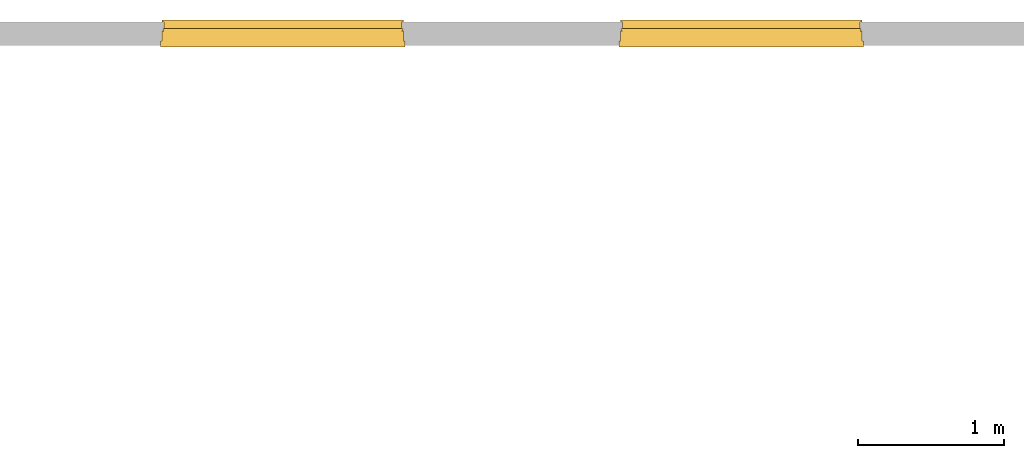
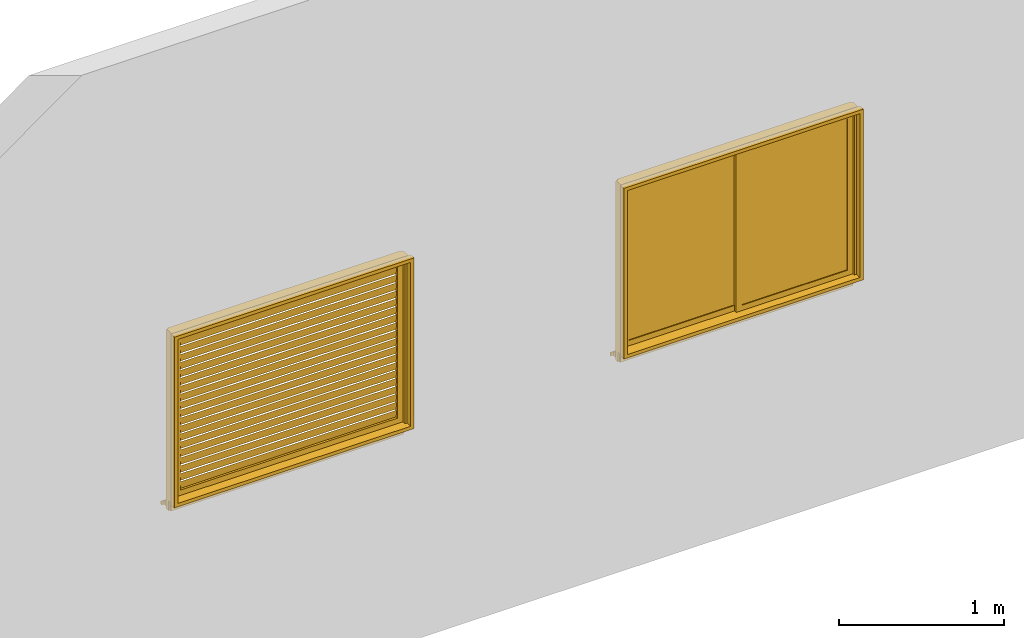
# One storey, part 2 of 3: 2 windows.
"""IFC2X3 building model written with IfcOpenShell, lengths in millimetres."""

from ifc_helpers import new_model, entity, si_unit, converted_unit, derived_unit, money_unit, direction, frame, origin_with_axes, place, context, subcontext, project, spatial, open_shell, faceted_brep, surface_model, type_object, element, save


model = new_model("IFC2X3")

# Units and contexts
model_context = context("Model", 3, precision=1e-05, world=origin_with_axes(), true_north=direction((0.0, 1.0)))
body_context = subcontext(model_context, "Body", "Model", "MODEL_VIEW")
ifc_project = project(units=[si_unit("LENGTHUNIT", "METRE", prefix="MILLI"), si_unit("AREAUNIT", "SQUARE_METRE"), si_unit("VOLUMEUNIT", "CUBIC_METRE"), converted_unit("PLANEANGLEUNIT", "DEGREE", entity("IfcPlaneAngleMeasure", 0.0174532925199), si_unit("PLANEANGLEUNIT", "RADIAN"), dimensions=[0, 0, 0, 0, 0, 0, 0]), si_unit("SOLIDANGLEUNIT", "STERADIAN"), money_unit("JPY"), converted_unit("TIMEUNIT", "Year", entity("IfcTimeMeasure", 31556926.0), si_unit("TIMEUNIT", "SECOND"), dimensions=[0, 0, 1, 0, 0, 0, 0]), si_unit("MASSUNIT", "GRAM", prefix="KILO"), si_unit("THERMODYNAMICTEMPERATUREUNIT", "DEGREE_CELSIUS"), si_unit("LUMINOUSINTENSITYUNIT", "LUMEN"), si_unit("ENERGYUNIT", "JOULE", prefix="MEGA"), derived_unit("THERMALCONDUCTANCEUNIT", [(si_unit("POWERUNIT", "WATT"), 1), (si_unit("LENGTHUNIT", "METRE"), -1), (si_unit("THERMODYNAMICTEMPERATUREUNIT", "KELVIN"), -1)]), derived_unit("SPECIFICHEATCAPACITYUNIT", [(si_unit("ENERGYUNIT", "JOULE"), 1), (si_unit("MASSUNIT", "GRAM", prefix="KILO"), -1), (si_unit("THERMODYNAMICTEMPERATUREUNIT", "KELVIN"), -1)]), derived_unit("MASSDENSITYUNIT", [(si_unit("MASSUNIT", "GRAM", prefix="KILO"), 1), (si_unit("VOLUMEUNIT", "CUBIC_METRE"), -1)])], contexts=[model_context])

# Site, building, storey
site_placement = place(None, origin_with_axes())
site = spatial("IfcSite", under=ifc_project, at=site_placement, CompositionType="ELEMENT")
building_placement = place(site_placement, origin_with_axes())
building = spatial("IfcBuilding", under=site, at=building_placement, CompositionType="ELEMENT")
storey_placement = place(building_placement, origin_with_axes())
storey = spatial("IfcBuildingStorey", under=building, at=storey_placement, Name="1FL", CompositionType="ELEMENT", Elevation=0.0)

# Windows
window_style_1 = type_object("IfcWindowStyle", ConstructionType="NOTDEFINED", OperationType="NOTDEFINED", ParameterTakesPrecedence=False, Sizeable=False)
window_1_placement = place(storey_placement, frame((-4117.13257315, -2483.59976003, 1600.0), z_axis=(0.0, 0.0, 1.0), x_axis=(1.0, 0.0, 0.0)))
element("IfcWindow", 1, at=window_1_placement, inside=storey, type_object=window_style_1, Name="AW2", OverallHeight=1350.0, OverallWidth=1720.0, context=body_context, shape_type="SurfaceModel", body=[
    faceted_brep([(0.0, -5.0, 0.0), (1600.0, -5.0, 0.0), (1600.0, -25.0, 0.0), (0.0, -25.0, 0.0), (0.0, -5.0, 1200.0), (1600.0, -5.0, 1200.0), (40.0, -5.0, 40.0), (1560.0, -5.0, 40.0), (1560.0, -5.0, 1160.0), (40.0, -5.0, 1160.0), (1600.0, -25.0, 1200.0), (0.0, -25.0, 1200.0), (40.0, -25.0, 40.0), (40.0, -25.0, 1160.0), (1560.0, -25.0, 1160.0), (1560.0, -25.0, 40.0)], [[[0, 1, 2, 3]], [[0, 4, 5, 1], [6, 7, 8, 9]], [[1, 5, 10, 2]], [[3, 2, 10, 11], [12, 13, 14, 15]], [[4, 0, 3, 11]], [[5, 4, 11, 10]], [[7, 6, 12, 15]], [[8, 7, 15, 14]], [[9, 8, 14, 13]], [[6, 9, 13, 12]]]),
    surface_model("IfcShellBasedSurfaceModel", [(1560.0, -9.86239832224, 40.336897219), (40.0, -9.86239832224, 40.336897219), (40.0, -20.1376016778, 98.610471202), (1560.0, -20.1376016778, 98.610471202)], [open_shell([[[0, 1, 2, 3]]])]),
    surface_model("IfcShellBasedSurfaceModel", [(1560.0, -9.86239832224, 99.2842656401), (40.0, -9.86239832224, 99.2842656401), (40.0, -20.1376016778, 157.557839623), (1560.0, -20.1376016778, 157.557839623)], [open_shell([[[0, 1, 2, 3]]])]),
    surface_model("IfcShellBasedSurfaceModel", [(1560.0, -9.86239832224, 158.231634061), (40.0, -9.86239832224, 158.231634061), (40.0, -20.1376016778, 216.505208044), (1560.0, -20.1376016778, 216.505208044)], [open_shell([[[0, 1, 2, 3]]])]),
    surface_model("IfcShellBasedSurfaceModel", [(1560.0, -9.86239832224, 217.179002482), (40.0, -9.86239832224, 217.179002482), (40.0, -20.1376016778, 275.452576465), (1560.0, -20.1376016778, 275.452576465)], [open_shell([[[0, 1, 2, 3]]])]),
    surface_model("IfcShellBasedSurfaceModel", [(1560.0, -9.86239832224, 276.126370903), (40.0, -9.86239832224, 276.126370903), (40.0, -20.1376016778, 334.399944886), (1560.0, -20.1376016778, 334.399944886)], [open_shell([[[0, 1, 2, 3]]])]),
    surface_model("IfcShellBasedSurfaceModel", [(1560.0, -9.86239832224, 335.073739324), (40.0, -9.86239832224, 335.073739324), (40.0, -20.1376016778, 393.347313307), (1560.0, -20.1376016778, 393.347313307)], [open_shell([[[0, 1, 2, 3]]])]),
    surface_model("IfcShellBasedSurfaceModel", [(1560.0, -9.86239832224, 394.021107745), (40.0, -9.86239832224, 394.021107745), (40.0, -20.1376016778, 452.294681728), (1560.0, -20.1376016778, 452.294681728)], [open_shell([[[0, 1, 2, 3]]])]),
    surface_model("IfcShellBasedSurfaceModel", [(1560.0, -9.86239832224, 452.968476166), (40.0, -9.86239832224, 452.968476166), (40.0, -20.1376016778, 511.242050149), (1560.0, -20.1376016778, 511.242050149)], [open_shell([[[0, 1, 2, 3]]])]),
    surface_model("IfcShellBasedSurfaceModel", [(1560.0, -9.86239832224, 511.915844587), (40.0, -9.86239832224, 511.915844587), (40.0, -20.1376016778, 570.18941857), (1560.0, -20.1376016778, 570.18941857)], [open_shell([[[0, 1, 2, 3]]])]),
    surface_model("IfcShellBasedSurfaceModel", [(1560.0, -9.86239832224, 570.863213009), (40.0, -9.86239832224, 570.863213009), (40.0, -20.1376016778, 629.136786991), (1560.0, -20.1376016778, 629.136786991)], [open_shell([[[0, 1, 2, 3]]])]),
    surface_model("IfcShellBasedSurfaceModel", [(1560.0, -9.86239832224, 629.81058143), (40.0, -9.86239832224, 629.81058143), (40.0, -20.1376016778, 688.084155413), (1560.0, -20.1376016778, 688.084155413)], [open_shell([[[0, 1, 2, 3]]])]),
    surface_model("IfcShellBasedSurfaceModel", [(1560.0, -9.86239832224, 688.757949851), (40.0, -9.86239832224, 688.757949851), (40.0, -20.1376016778, 747.031523834), (1560.0, -20.1376016778, 747.031523834)], [open_shell([[[0, 1, 2, 3]]])]),
    surface_model("IfcShellBasedSurfaceModel", [(1560.0, -9.86239832224, 747.705318272), (40.0, -9.86239832224, 747.705318272), (40.0, -20.1376016778, 805.978892255), (1560.0, -20.1376016778, 805.978892255)], [open_shell([[[0, 1, 2, 3]]])]),
    surface_model("IfcShellBasedSurfaceModel", [(1560.0, -9.86239832224, 806.652686693), (40.0, -9.86239832224, 806.652686693), (40.0, -20.1376016778, 864.926260676), (1560.0, -20.1376016778, 864.926260676)], [open_shell([[[0, 1, 2, 3]]])]),
    surface_model("IfcShellBasedSurfaceModel", [(1560.0, -9.86239832224, 865.600055114), (40.0, -9.86239832224, 865.600055114), (40.0, -20.1376016778, 923.873629097), (1560.0, -20.1376016778, 923.873629097)], [open_shell([[[0, 1, 2, 3]]])]),
    surface_model("IfcShellBasedSurfaceModel", [(1560.0, -9.86239832224, 924.547423535), (40.0, -9.86239832224, 924.547423535), (40.0, -20.1376016778, 982.820997518), (1560.0, -20.1376016778, 982.820997518)], [open_shell([[[0, 1, 2, 3]]])]),
    surface_model("IfcShellBasedSurfaceModel", [(1560.0, -9.86239832224, 983.494791956), (40.0, -9.86239832224, 983.494791956), (40.0, -20.1376016778, 1041.76836594), (1560.0, -20.1376016778, 1041.76836594)], [open_shell([[[0, 1, 2, 3]]])]),
    surface_model("IfcShellBasedSurfaceModel", [(1560.0, -9.86239832224, 1042.44216038), (40.0, -9.86239832224, 1042.44216038), (40.0, -20.1376016778, 1100.71573436), (1560.0, -20.1376016778, 1100.71573436)], [open_shell([[[0, 1, 2, 3]]])]),
    surface_model("IfcShellBasedSurfaceModel", [(1560.0, -9.86239832224, 1101.3895288), (40.0, -9.86239832224, 1101.3895288), (40.0, -20.1376016778, 1159.66310278), (1560.0, -20.1376016778, 1159.66310278)], [open_shell([[[0, 1, 2, 3]]])]),
    faceted_brep([(1630.0, 20.0, -30.0), (1630.0, -50.0, -30.0), (-30.0, -50.0, -30.0), (-30.0, 20.0, -30.0), (1630.0, 20.0, 1230.0), (1630.0, -50.0, 1230.0), (-30.0, -50.0, 1230.0), (1600.0, -50.0, 0.0), (0.0, -50.0, 0.0), (0.0, -50.0, 1200.0), (1600.0, -50.0, 1200.0), (-30.0, 20.0, 1230.0), (1600.0, 20.0, 0.0), (1600.0, 20.0, 1200.0), (0.0, 20.0, 1200.0), (0.0, 20.0, 0.0)], [[[0, 1, 2, 3]], [[4, 5, 1, 0]], [[1, 5, 6, 2], [7, 8, 9, 10]], [[3, 2, 6, 11]], [[0, 3, 11, 4], [12, 13, 14, 15]], [[11, 6, 5, 4]], [[15, 8, 7, 12]], [[14, 9, 8, 15]], [[13, 10, 9, 14]], [[12, 7, 10, 13]]]),
    faceted_brep([(-40.0, -50.0, 1215.0), (-40.0, -90.0, 1215.0), (-40.0, -90.0, 1240.0), (-40.0, -50.0, 1240.0), (1640.0, -50.0, 1215.0), (1640.0, -90.0, 1215.0), (1640.0, -90.0, 1240.0), (1640.0, -50.0, 1240.0)], [[[0, 1, 2, 3]], [[4, 5, 1, 0]], [[1, 5, 6, 2]], [[3, 2, 6, 7]], [[0, 3, 7, 4]], [[7, 6, 5, 4]]]),
    faceted_brep([(1615.0, -50.0, 0.0), (1615.0, -90.0, 0.0), (1615.0, -90.0, 1215.0), (1615.0, -50.0, 1215.0), (1640.0, -50.0, 0.0), (1640.0, -90.0, 0.0), (1640.0, -90.0, 1215.0), (1640.0, -50.0, 1215.0)], [[[0, 1, 2, 3]], [[4, 5, 1, 0]], [[1, 5, 6, 2]], [[3, 2, 6, 7]], [[0, 3, 7, 4]], [[7, 6, 5, 4]]]),
    faceted_brep([(-40.0, -50.0, 0.0), (-40.0, -90.0, 0.0), (-40.0, -90.0, 1215.0), (-40.0, -50.0, 1215.0), (-15.0, -50.0, 0.0), (-15.0, -90.0, 0.0), (-15.0, -90.0, 1215.0), (-15.0, -50.0, 1215.0)], [[[0, 1, 2, 3]], [[4, 5, 1, 0]], [[1, 5, 6, 2]], [[3, 2, 6, 7]], [[0, 3, 7, 4]], [[7, 6, 5, 4]]]),
    faceted_brep([(1640.0, -50.0, -25.0), (1640.0, -90.0, -25.0), (-40.0, -90.0, -25.0), (-40.0, -50.0, -25.0), (1640.0, -50.0, 0.0), (1640.0, -90.0, 0.0), (1615.0, -90.0, 0.0), (-15.0, -90.0, 0.0), (-40.0, -90.0, 0.0), (-40.0, -50.0, 0.0), (-15.0, -50.0, 0.0), (1615.0, -50.0, 0.0)], [[[0, 1, 2, 3]], [[4, 5, 1, 0]], [[1, 5, 6, 7, 8, 2]], [[3, 2, 8, 9]], [[0, 3, 9, 10, 11, 4]], [[11, 6, 5, 4]], [[10, 7, 6, 11]], [[9, 8, 7, 10]]]),
    faceted_brep([(-25.0, 35.0, -110.0), (-15.0, 35.0, -110.0), (-15.0, 5.0, -110.0), (-25.0, 5.0, -110.0), (-25.0, 35.0, 1215.0), (-15.0, 35.0, 1215.0), (-15.0, 20.0, 1215.0), (-15.0, 20.0, -30.0), (-15.0, 5.0, -30.0), (-25.0, 5.0, -30.0), (-25.0, 20.0, -30.0), (-25.0, 20.0, 1215.0)], [[[0, 1, 2, 3]], [[4, 5, 1, 0]], [[1, 5, 6, 7, 8, 2]], [[3, 2, 8, 9]], [[0, 3, 9, 10, 11, 4]], [[11, 6, 5, 4]], [[10, 7, 6, 11]], [[9, 8, 7, 10]]]),
    faceted_brep([(1615.0, 35.0, -110.0), (1625.0, 35.0, -110.0), (1625.0, 5.0, -110.0), (1615.0, 5.0, -110.0), (1615.0, 35.0, 1215.0), (1625.0, 35.0, 1215.0), (1625.0, 20.0, 1215.0), (1625.0, 20.0, -30.0), (1625.0, 5.0, -30.0), (1615.0, 5.0, -30.0), (1615.0, 20.0, -30.0), (1615.0, 20.0, 1215.0)], [[[0, 1, 2, 3]], [[4, 5, 1, 0]], [[1, 5, 6, 7, 8, 2]], [[3, 2, 8, 9]], [[0, 3, 9, 10, 11, 4]], [[11, 6, 5, 4]], [[10, 7, 6, 11]], [[9, 8, 7, 10]]]),
    faceted_brep([(1615.0, 20.0, 1215.0), (1615.0, 20.0, 1225.0), (-15.0, 20.0, 1225.0), (-15.0, 20.0, 1215.0), (1615.0, 35.0, 1215.0), (1615.0, 35.0, 1225.0), (-15.0, 35.0, 1225.0), (-15.0, 35.0, 1215.0)], [[[0, 1, 2, 3]], [[4, 5, 1, 0]], [[1, 5, 6, 2]], [[3, 2, 6, 7]], [[0, 3, 7, 4]], [[7, 6, 5, 4]]]),
    faceted_brep([(-15.0, 5.0, -40.0), (1615.0, 5.0, -40.0), (1615.0, 80.0, -81.6666666667), (1630.0, 80.0, -81.6666666667), (1630.0, 95.0, -90.0), (-30.0, 95.0, -90.0), (-30.0, 80.0, -81.6666666667), (-15.0, 80.0, -81.6666666667), (-15.0, 5.0, -30.0), (1615.0, 5.0, -30.0), (1615.0, -5.0, -30.0), (1615.0, -5.0, -110.0), (1615.0, 80.0, -110.0), (1630.0, 80.0, -110.0), (1630.0, 95.0, -110.0), (-30.0, 95.0, -110.0), (-30.0, 80.0, -110.0), (-15.0, 80.0, -110.0), (-15.0, -5.0, -110.0), (-15.0, -5.0, -30.0)], [[[0, 1, 2, 3, 4, 5, 6, 7]], [[8, 9, 1, 0]], [[1, 9, 10, 11, 12, 2]], [[3, 2, 12, 13]], [[3, 13, 14, 4]], [[14, 15, 5, 4]], [[6, 5, 15, 16]], [[16, 17, 7, 6]], [[8, 0, 7, 17, 18, 19]], [[19, 10, 9, 8]], [[18, 11, 10, 19]], [[17, 16, 15, 14, 13, 12, 11, 18]]]),
])
window_style_2 = type_object("IfcWindowStyle", ConstructionType="NOTDEFINED", OperationType="NOTDEFINED", ParameterTakesPrecedence=False, Sizeable=False)
window_2_placement = place(storey_placement, frame((-967.049227494, -2483.59976003, 1600.0), z_axis=(0.0, 0.0, 1.0), x_axis=(1.0, 0.0, 0.0)))
element("IfcWindow", 2, at=window_2_placement, inside=storey, type_object=window_style_2, Name="AW4", OverallHeight=1350.0, OverallWidth=1720.0, context=body_context, shape_type="Brep", body=[
    faceted_brep([(0.0, 5.0, 0.0), (820.0, 5.0, 0.0), (820.0, -15.0, 0.0), (0.0, -15.0, 0.0), (0.0, 5.0, 1200.0), (820.0, 5.0, 1200.0), (40.0, 5.0, 40.0), (780.0, 5.0, 40.0), (780.0, 5.0, 1160.0), (40.0, 5.0, 1160.0), (820.0, -15.0, 1200.0), (0.0, -15.0, 1200.0), (40.0, -15.0, 40.0), (40.0, -15.0, 1160.0), (780.0, -15.0, 1160.0), (780.0, -15.0, 40.0)], [[[0, 1, 2, 3]], [[0, 4, 5, 1], [6, 7, 8, 9]], [[1, 5, 10, 2]], [[3, 2, 10, 11], [12, 13, 14, 15]], [[4, 0, 3, 11]], [[5, 4, 11, 10]], [[7, 6, 12, 15]], [[8, 7, 15, 14]], [[9, 8, 14, 13]], [[6, 9, 13, 12]]]),
    faceted_brep([(780.0, -15.0, 0.0), (1600.0, -15.0, 0.0), (1600.0, -35.0, 0.0), (780.0, -35.0, 0.0), (780.0, -15.0, 1200.0), (1600.0, -15.0, 1200.0), (820.0, -15.0, 40.0), (1560.0, -15.0, 40.0), (1560.0, -15.0, 1160.0), (820.0, -15.0, 1160.0), (1600.0, -35.0, 1200.0), (780.0, -35.0, 1200.0), (820.0, -35.0, 40.0), (820.0, -35.0, 1160.0), (1560.0, -35.0, 1160.0), (1560.0, -35.0, 40.0)], [[[0, 1, 2, 3]], [[0, 4, 5, 1], [6, 7, 8, 9]], [[1, 5, 10, 2]], [[3, 2, 10, 11], [12, 13, 14, 15]], [[4, 0, 3, 11]], [[5, 4, 11, 10]], [[7, 6, 12, 15]], [[8, 7, 15, 14]], [[9, 8, 14, 13]], [[6, 9, 13, 12]]]),
    faceted_brep([(40.0, -1.0, 40.0), (780.0, -1.0, 40.0), (780.0, -9.0, 40.0), (40.0, -9.0, 40.0), (40.0, -0.999999999999, 1160.0), (780.0, -0.999999999999, 1160.0), (780.0, -9.0, 1160.0), (40.0, -9.0, 1160.0)], [[[0, 1, 2, 3]], [[0, 4, 5, 1]], [[1, 5, 6, 2]], [[3, 2, 6, 7]], [[4, 0, 3, 7]], [[5, 4, 7, 6]]]),
    faceted_brep([(820.0, -21.0, 40.0), (1560.0, -21.0, 40.0), (1560.0, -29.0, 40.0), (820.0, -29.0, 40.0), (820.0, -21.0, 1160.0), (1560.0, -21.0, 1160.0), (1560.0, -29.0, 1160.0), (820.0, -29.0, 1160.0)], [[[0, 1, 2, 3]], [[0, 4, 5, 1]], [[1, 5, 6, 2]], [[3, 2, 6, 7]], [[4, 0, 3, 7]], [[5, 4, 7, 6]]]),
    faceted_brep([(-30.0, 20.0, -30.0), (1630.0, 20.0, -30.0), (1630.0, -50.0, -30.0), (-30.0, -50.0, -30.0), (-30.0, 20.0, 1230.0), (1630.0, 20.0, 1230.0), (0.0, 20.0, 0.0), (1600.0, 20.0, 0.0), (1600.0, 20.0, 1200.0), (0.0, 20.0, 1200.0), (1630.0, -50.0, 1230.0), (-30.0, -50.0, 1230.0), (0.0, -50.0, 0.0), (0.0, -50.0, 1200.0), (1600.0, -50.0, 1200.0), (1600.0, -50.0, 0.0)], [[[0, 1, 2, 3]], [[0, 4, 5, 1], [6, 7, 8, 9]], [[1, 5, 10, 2]], [[3, 2, 10, 11], [12, 13, 14, 15]], [[4, 0, 3, 11]], [[5, 4, 11, 10]], [[7, 6, 12, 15]], [[8, 7, 15, 14]], [[9, 8, 14, 13]], [[6, 9, 13, 12]]]),
    faceted_brep([(1640.0, -50.0, 1215.0), (1640.0, -50.0, 1240.0), (1640.0, -90.0, 1240.0), (1640.0, -90.0, 1215.0), (-40.0, -50.0, 1215.0), (-40.0, -50.0, 1240.0), (-40.0, -90.0, 1240.0), (-40.0, -90.0, 1215.0)], [[[0, 1, 2, 3]], [[0, 4, 5, 1]], [[1, 5, 6, 2]], [[3, 2, 6, 7]], [[4, 0, 3, 7]], [[5, 4, 7, 6]]]),
    faceted_brep([(-15.0, -50.0, 0.0), (-15.0, -50.0, 1215.0), (-15.0, -90.0, 1215.0), (-15.0, -90.0, 0.0), (-40.0, -50.0, 0.0), (-40.0, -50.0, 1215.0), (-40.0, -90.0, 1215.0), (-40.0, -90.0, 0.0)], [[[0, 1, 2, 3]], [[0, 4, 5, 1]], [[1, 5, 6, 2]], [[3, 2, 6, 7]], [[4, 0, 3, 7]], [[5, 4, 7, 6]]]),
    faceted_brep([(1640.0, -50.0, 0.0), (1640.0, -50.0, 1215.0), (1640.0, -90.0, 1215.0), (1640.0, -90.0, 0.0), (1615.0, -50.0, 0.0), (1615.0, -50.0, 1215.0), (1615.0, -90.0, 1215.0), (1615.0, -90.0, 0.0)], [[[0, 1, 2, 3]], [[0, 4, 5, 1]], [[1, 5, 6, 2]], [[3, 2, 6, 7]], [[4, 0, 3, 7]], [[5, 4, 7, 6]]]),
    faceted_brep([(-40.0, -50.0, -25.0), (1640.0, -50.0, -25.0), (1640.0, -90.0, -25.0), (-40.0, -90.0, -25.0), (-40.0, -50.0, 0.0), (-15.0, -50.0, 0.0), (1615.0, -50.0, 0.0), (1640.0, -50.0, 0.0), (1640.0, -90.0, 0.0), (1615.0, -90.0, 0.0), (-15.0, -90.0, 0.0), (-40.0, -90.0, 0.0)], [[[0, 1, 2, 3]], [[0, 4, 5, 6, 7, 1]], [[1, 7, 8, 2]], [[3, 2, 8, 9, 10, 11]], [[4, 0, 3, 11]], [[5, 4, 11, 10]], [[6, 5, 10, 9]], [[7, 6, 9, 8]]]),
    faceted_brep([(1625.0, 35.0, -110.0), (1625.0, 5.0, -110.0), (1615.0, 5.0, -110.0), (1615.0, 35.0, -110.0), (1625.0, 35.0, 1215.0), (1625.0, 20.0, 1215.0), (1625.0, 20.0, -30.0), (1625.0, 5.0, -30.0), (1615.0, 5.0, -30.0), (1615.0, 20.0, -30.0), (1615.0, 20.0, 1215.0), (1615.0, 35.0, 1215.0)], [[[0, 1, 2, 3]], [[0, 4, 5, 6, 7, 1]], [[1, 7, 8, 2]], [[3, 2, 8, 9, 10, 11]], [[4, 0, 3, 11]], [[5, 4, 11, 10]], [[6, 5, 10, 9]], [[7, 6, 9, 8]]]),
    faceted_brep([(-15.0, 35.0, -110.0), (-15.0, 5.0, -110.0), (-25.0, 5.0, -110.0), (-25.0, 35.0, -110.0), (-15.0, 35.0, 1215.0), (-15.0, 20.0, 1215.0), (-15.0, 20.0, -30.0), (-15.0, 5.0, -30.0), (-25.0, 5.0, -30.0), (-25.0, 20.0, -30.0), (-25.0, 20.0, 1215.0), (-25.0, 35.0, 1215.0)], [[[0, 1, 2, 3]], [[0, 4, 5, 6, 7, 1]], [[1, 7, 8, 2]], [[3, 2, 8, 9, 10, 11]], [[4, 0, 3, 11]], [[5, 4, 11, 10]], [[6, 5, 10, 9]], [[7, 6, 9, 8]]]),
    faceted_brep([(-15.0, 20.0, 1215.0), (1615.0, 20.0, 1215.0), (1615.0, 20.0, 1225.0), (-15.0, 20.0, 1225.0), (-15.0, 35.0, 1215.0), (1615.0, 35.0, 1215.0), (1615.0, 35.0, 1225.0), (-15.0, 35.0, 1225.0)], [[[0, 1, 2, 3]], [[0, 4, 5, 1]], [[1, 5, 6, 2]], [[3, 2, 6, 7]], [[4, 0, 3, 7]], [[5, 4, 7, 6]]]),
    faceted_brep([(1615.0, 5.0, -40.0), (1615.0, 80.0, -81.6666666667), (1630.0, 80.0, -81.6666666667), (1630.0, 95.0, -90.0), (-30.0, 95.0, -90.0), (-30.0, 80.0, -81.6666666667), (-15.0, 80.0, -81.6666666667), (-15.0, 5.0, -40.0), (1615.0, 5.0, -30.0), (1615.0, -5.0, -30.0), (1615.0, -5.0, -110.0), (1615.0, 80.0, -110.0), (1630.0, 80.0, -110.0), (1630.0, 95.0, -110.0), (-30.0, 95.0, -110.0), (-30.0, 80.0, -110.0), (-15.0, 80.0, -110.0), (-15.0, -5.0, -110.0), (-15.0, -5.0, -30.0), (-15.0, 5.0, -30.0)], [[[0, 1, 2, 3, 4, 5, 6, 7]], [[8, 9, 10, 11, 1, 0]], [[12, 2, 1, 11]], [[2, 12, 13, 3]], [[14, 4, 3, 13]], [[5, 4, 14, 15]], [[5, 15, 16, 6]], [[7, 6, 16, 17, 18, 19]], [[8, 0, 7, 19]], [[9, 8, 19, 18]], [[10, 9, 18, 17]], [[11, 10, 17, 16, 15, 14, 13, 12]]]),
])

save(model, "model.ifc")
